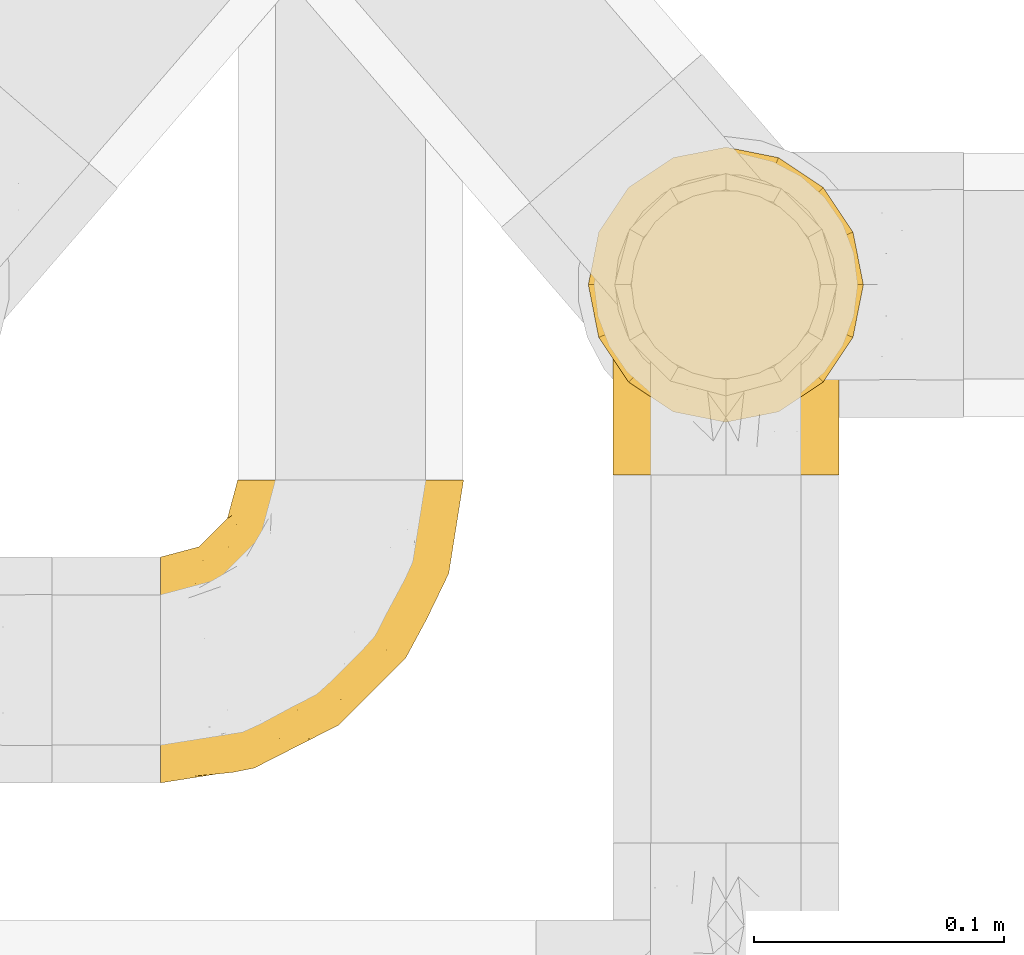
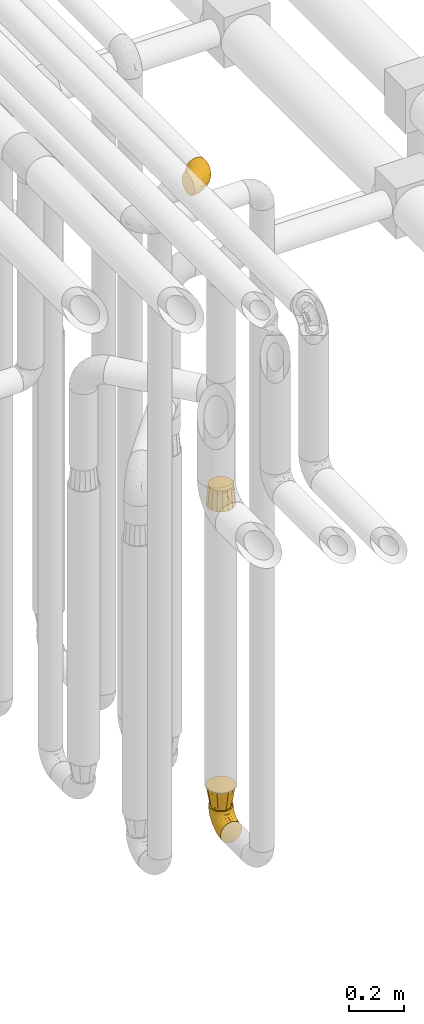
# One storey, part 196 of 827: 4 coverings.
"""IFC2X3 building model written with IfcOpenShell, lengths in millimetres."""

from ifc_helpers import new_model, entity, si_unit, converted_unit, derived_unit, direction, frame, origin, place, context, subcontext, project, spatial, faceted_brep, element, save


model = new_model("IFC2X3")

# Units and contexts
model_context = context("Model", 3, precision=0.01, world=origin(), true_north=direction((6.12303176911189e-17, 1.0)))
body_context = subcontext(model_context, "Body", "Model", "MODEL_VIEW")
ifc_project = project(units=[si_unit("LENGTHUNIT", "METRE", prefix="MILLI"), si_unit("AREAUNIT", "SQUARE_METRE"), si_unit("VOLUMEUNIT", "CUBIC_METRE"), converted_unit("PLANEANGLEUNIT", "DEGREE", entity("IfcRatioMeasure", 0.0174532925199433), si_unit("PLANEANGLEUNIT", "RADIAN"), dimensions=[0, 0, 0, 0, 0, 0, 0]), si_unit("MASSUNIT", "GRAM", prefix="KILO"), derived_unit("MASSDENSITYUNIT", [(si_unit("MASSUNIT", "GRAM", prefix="KILO"), 1), (si_unit("LENGTHUNIT", "METRE"), -3)]), derived_unit("MOMENTOFINERTIAUNIT", [(si_unit("LENGTHUNIT", "METRE"), 4)]), si_unit("TIMEUNIT", "SECOND"), si_unit("FREQUENCYUNIT", "HERTZ"), si_unit("THERMODYNAMICTEMPERATUREUNIT", "DEGREE_CELSIUS"), derived_unit("THERMALTRANSMITTANCEUNIT", [(si_unit("MASSUNIT", "GRAM", prefix="KILO"), 1), (si_unit("THERMODYNAMICTEMPERATUREUNIT", "KELVIN"), -1), (si_unit("TIMEUNIT", "SECOND"), -3)]), derived_unit("VOLUMETRICFLOWRATEUNIT", [(si_unit("LENGTHUNIT", "METRE"), 3), (si_unit("TIMEUNIT", "SECOND"), -1)]), derived_unit("MASSFLOWRATEUNIT", [(si_unit("MASSUNIT", "GRAM", prefix="KILO"), 1), (si_unit("TIMEUNIT", "SECOND"), -1)]), derived_unit("ROTATIONALFREQUENCYUNIT", [(si_unit("TIMEUNIT", "SECOND"), -1)]), si_unit("ELECTRICCURRENTUNIT", "AMPERE"), si_unit("ELECTRICVOLTAGEUNIT", "VOLT"), si_unit("POWERUNIT", "WATT"), si_unit("FORCEUNIT", "NEWTON", prefix="KILO"), si_unit("ILLUMINANCEUNIT", "LUX"), si_unit("LUMINOUSFLUXUNIT", "LUMEN"), si_unit("LUMINOUSINTENSITYUNIT", "CANDELA"), derived_unit("USERDEFINED", [(si_unit("MASSUNIT", "GRAM", prefix="KILO"), -1), (si_unit("LENGTHUNIT", "METRE"), -2), (si_unit("TIMEUNIT", "SECOND"), 3), (si_unit("LUMINOUSFLUXUNIT", "LUMEN"), 1)]), derived_unit("LINEARVELOCITYUNIT", [(si_unit("LENGTHUNIT", "METRE"), 1), (si_unit("TIMEUNIT", "SECOND"), -1)]), si_unit("PRESSUREUNIT", "PASCAL"), derived_unit("USERDEFINED", [(si_unit("LENGTHUNIT", "METRE"), -2), (si_unit("MASSUNIT", "GRAM", prefix="KILO"), 1), (si_unit("TIMEUNIT", "SECOND"), -2)]), derived_unit("LINEARFORCEUNIT", [(si_unit("MASSUNIT", "GRAM", prefix="KILO"), 1), (si_unit("LENGTHUNIT", "METRE"), 1), (si_unit("TIMEUNIT", "SECOND"), -2), (si_unit("LENGTHUNIT", "METRE"), -1)]), derived_unit("PLANARFORCEUNIT", [(si_unit("MASSUNIT", "GRAM", prefix="KILO"), 1), (si_unit("LENGTHUNIT", "METRE"), 1), (si_unit("TIMEUNIT", "SECOND"), -2), (si_unit("LENGTHUNIT", "METRE"), -2)])], contexts=[model_context])

# Site, building, storey
site_placement = place(None, origin())
site = spatial("IfcSite", under=ifc_project, at=site_placement, CompositionType="ELEMENT")
building_placement = place(site_placement, origin())
building = spatial("IfcBuilding", under=site, at=building_placement, CompositionType="ELEMENT")
storey_placement = place(building_placement, frame((0.0, 0.0, 28200.0)))
storey = spatial("IfcBuildingStorey", under=building, at=storey_placement, Name="08", CompositionType="ELEMENT", Elevation=28200.0)

# Coverings
covering_1_placement = place(storey_placement, frame((36928.29, 10002.61, 353.25)))
element("IfcCovering", 1, at=covering_1_placement, inside=storey, Name=":ADSK_", ObjectType=":ADSK_", PredefinedType="INSULATION", context=body_context, shape_type="Brep", body=[
    faceted_brep([(90.76, 87.65, 122.75), (87.42, 97.19, 122.75), (82.04, 105.75, 122.75), (74.89, 112.9, 122.75), (66.33, 118.28, 122.75), (56.79, 121.61, 122.75), (46.75, 122.75, 122.75), (36.69, 121.61, 122.75), (27.15, 118.27, 122.75), (18.59, 112.89, 122.75), (11.44, 105.74, 122.75), (6.06, 97.18, 122.75), (2.73, 87.64, 122.75), (1.6, 77.6, 122.75), (2.73, 67.54, 122.75), (6.07, 58.0, 122.75), (11.45, 49.44, 122.75), (18.6, 42.29, 122.75), (27.16, 36.91, 122.75), (36.7, 33.58, 122.75), (46.75, 32.45, 122.75), (56.8, 33.58, 122.75), (66.34, 36.92, 122.75), (74.9, 42.3, 122.75), (82.05, 49.45, 122.75), (87.43, 58.01, 122.75), (90.76, 67.55, 122.75), (91.9, 77.6, 122.75), (35.06, 1.6, 90.36), (24.17, 1.6, 85.85), (14.82, 1.6, 78.67), (7.64, 1.6, 69.32), (3.13, 1.6, 58.43), (1.6, 1.6, 46.75), (3.13, 1.6, 35.06), (7.64, 1.6, 24.17), (14.82, 1.6, 14.82), (24.17, 1.6, 7.64), (35.06, 1.6, 3.13), (46.75, 1.6, 1.6), (58.43, 1.6, 3.13), (69.32, 1.6, 7.64), (78.67, 1.6, 14.82), (85.85, 1.6, 24.17), (90.36, 1.6, 35.06), (91.9, 1.6, 46.75), (90.36, 1.6, 58.43), (85.85, 1.6, 69.32), (78.67, 1.6, 78.67), (69.32, 1.6, 85.85), (58.43, 1.6, 90.36), (46.75, 1.6, 91.9), (46.75, 99.61, 51.54), (55.2, 95.26, 47.17), (46.75, 86.21, 38.13), (46.75, 39.03, 7.52), (54.53, 30.75, 5.85), (46.75, 23.8, 5.11), (59.63, 60.8, 19.2), (62.07, 85.37, 38.98), (71.86, 73.64, 35.02), (62.65, 31.01, 8.21), (71.33, 49.14, 19.28), (72.93, 23.88, 12.19), (91.2, 82.74, 101.39), (86.31, 43.48, 34.43), (80.89, 29.47, 20.95), (79.49, 56.38, 30.74), (90.68, 72.18, 72.93), (86.84, 72.24, 56.64), (87.38, 87.6, 80.81), (76.87, 107.24, 93.43), (83.73, 101.1, 100.76), (81.03, 95.16, 74.27), (91.9, 71.81, 93.66), (91.9, 63.57, 81.33), (91.9, 55.34, 69.01), (91.03, 23.66, 40.87), (87.58, 20.55, 29.38), (56.52, 107.97, 67.05), (46.75, 116.82, 85.31), (60.4, 117.03, 93.68), (91.9, 30.68, 52.53), (91.9, 21.51, 50.71), (91.9, 12.33, 48.88), (67.87, 106.17, 72.77), (90.35, 52.37, 51.21), (69.57, 114.51, 101.18), (46.75, 119.23, 100.54), (79.91, 78.37, 48.74), (91.9, 75.46, 112.01), (91.9, 73.63, 102.83), (74.99, 101.51, 73.88), (46.75, 72.81, 24.73), (91.9, 43.01, 60.77), (88.53, 92.6, 103.08), (72.65, 91.86, 54.8), (46.75, 55.92, 16.13), (62.97, 99.01, 55.92), (46.75, 108.21, 68.42), (66.2, 32.05, 104.98), (56.6, 30.22, 108.58), (59.89, 23.37, 98.21), (90.95, 28.43, 61.56), (90.22, 16.44, 60.69), (76.64, 37.1, 100.0), (71.58, 28.88, 95.88), (79.99, 33.93, 90.81), (89.54, 50.17, 84.88), (89.97, 40.57, 73.29), (81.32, 47.62, 113.4), (74.56, 39.9, 109.8), (84.15, 47.92, 102.13), (90.37, 34.27, 67.29), (87.82, 24.65, 70.34), (90.98, 62.6, 95.15), (90.96, 66.18, 105.49), (85.14, 11.74, 71.5), (58.11, 13.89, 92.87), (46.75, 17.02, 96.03), (78.39, 15.86, 81.34), (88.22, 57.71, 107.44), (66.06, 9.11, 88.36), (68.6, 18.55, 90.43), (63.78, 34.74, 114.37), (88.42, 54.95, 98.41), (90.61, 57.35, 88.73), (83.8, 22.03, 76.89), (77.98, 24.8, 86.08), (91.22, 69.07, 112.64), (83.46, 42.31, 94.21), (46.75, 29.63, 112.22), (46.75, 28.31, 107.32), (84.66, 30.23, 79.95), (86.33, 40.13, 84.51), (46.75, 22.67, 101.67), (46.75, 12.12, 94.71), (15.1, 15.86, 81.34), (9.69, 22.03, 76.89), (15.52, 24.8, 86.08), (8.83, 30.23, 79.96), (35.39, 13.88, 92.87), (12.18, 47.61, 113.41), (1.6, 73.63, 102.83), (2.53, 66.17, 105.5), (2.27, 69.07, 112.64), (36.9, 30.22, 108.58), (27.31, 32.04, 104.98), (33.62, 23.36, 98.2), (5.07, 54.93, 98.4), (9.36, 47.91, 102.13), (5.27, 57.69, 107.44), (27.43, 9.1, 88.36), (1.6, 21.51, 50.71), (1.6, 12.33, 48.88), (10.05, 42.29, 94.22), (16.87, 37.09, 100.01), (8.35, 11.74, 71.5), (3.27, 16.44, 60.69), (1.6, 30.68, 52.53), (21.94, 28.86, 95.89), (29.72, 34.74, 114.37), (1.6, 63.57, 81.33), (1.6, 55.34, 69.01), (3.96, 50.17, 84.88), (1.6, 75.46, 112.01), (18.95, 39.89, 109.8), (2.54, 28.43, 61.56), (3.12, 34.27, 67.29), (1.6, 43.01, 60.77), (2.51, 62.59, 95.14), (3.52, 40.57, 73.29), (7.17, 40.13, 84.53), (1.6, 71.81, 93.66), (13.52, 33.92, 90.82), (2.88, 57.34, 88.73), (5.67, 24.65, 70.34), (24.89, 18.54, 90.43), (12.6, 29.47, 20.95), (7.18, 43.48, 34.43), (14.0, 56.4, 30.74), (22.16, 49.17, 19.29), (21.61, 73.69, 35.07), (3.14, 52.37, 51.21), (6.65, 72.26, 56.67), (20.82, 91.88, 54.85), (31.41, 85.36, 38.98), (5.91, 20.55, 29.38), (2.46, 23.66, 40.87), (33.87, 60.8, 19.2), (30.84, 31.02, 8.21), (38.96, 30.75, 5.85), (20.56, 23.9, 12.19), (2.81, 72.17, 72.93), (6.1, 87.59, 80.83), (2.29, 82.74, 101.39), (33.08, 117.03, 93.69), (16.61, 107.23, 93.43), (36.96, 107.97, 67.04), (9.75, 101.08, 100.76), (25.61, 106.17, 72.78), (30.5, 99.01, 55.93), (23.91, 114.5, 101.18), (12.45, 95.15, 74.27), (18.49, 101.5, 73.89), (4.96, 92.59, 103.09), (13.56, 78.38, 48.78), (38.28, 95.27, 47.19)], [[[0, 1, 2, 3, 4, 5, 6, 7, 8, 9, 10, 11, 12, 13, 14, 15, 16, 17, 18, 19, 20, 21, 22, 23, 24, 25, 26, 27]], [[28, 29, 30, 31, 32, 33, 34, 35, 36, 37, 38, 39, 40, 41, 42, 43, 44, 45, 46, 47, 48, 49, 50, 51]], [[52, 53, 54]], [[55, 56, 57]], [[58, 59, 60]], [[61, 62, 63]], [[27, 64, 0]], [[65, 66, 67]], [[41, 40, 61]], [[68, 69, 70]], [[66, 43, 42]], [[63, 42, 41]], [[71, 72, 73]], [[72, 2, 1]], [[68, 74, 75, 76]], [[45, 44, 77]], [[43, 78, 44]], [[79, 80, 81]], [[77, 82, 83, 84, 45]], [[79, 81, 85]], [[71, 2, 72]], [[65, 86, 77]], [[4, 81, 5]], [[66, 65, 78]], [[4, 3, 87]], [[81, 88, 5]], [[63, 66, 42]], [[68, 70, 64]], [[67, 60, 89]], [[71, 3, 2]], [[64, 27, 90, 91, 74]], [[92, 71, 73]], [[40, 57, 56]], [[59, 93, 54]], [[86, 76, 94, 82]], [[1, 0, 95]], [[58, 62, 61]], [[60, 96, 89]], [[85, 81, 87]], [[56, 97, 58]], [[65, 67, 69]], [[87, 81, 4]], [[67, 89, 69]], [[61, 63, 41]], [[95, 72, 1]], [[73, 72, 70]], [[69, 73, 70]], [[73, 89, 96]], [[3, 71, 87]], [[85, 87, 71]], [[58, 61, 56]], [[59, 58, 93]], [[76, 86, 68]], [[69, 89, 73]], [[68, 86, 69]], [[65, 69, 86]], [[68, 64, 74]], [[95, 64, 70]], [[98, 79, 85]], [[79, 52, 99, 80]], [[66, 62, 67]], [[62, 58, 60]], [[62, 60, 67]], [[59, 98, 96]], [[59, 96, 60]], [[96, 85, 92]], [[88, 81, 80]], [[88, 6, 5]], [[66, 63, 62]], [[64, 95, 0]], [[72, 95, 70]], [[77, 44, 78]], [[86, 82, 77]], [[40, 39, 57]], [[96, 98, 85]], [[40, 56, 61]], [[66, 78, 43]], [[77, 78, 65]], [[79, 98, 53]], [[96, 92, 73]], [[85, 71, 92]], [[97, 56, 55]], [[97, 93, 58]], [[53, 98, 59]], [[54, 53, 59]], [[79, 53, 52]], [[100, 101, 102]], [[46, 45, 84, 83]], [[103, 104, 82]], [[82, 104, 83]], [[105, 106, 107]], [[108, 109, 76]], [[110, 111, 112]], [[103, 113, 114]], [[115, 74, 116]], [[48, 47, 117]], [[118, 102, 119]], [[49, 48, 120]], [[74, 91, 116]], [[116, 121, 115]], [[49, 122, 50]], [[123, 106, 102]], [[124, 111, 22]], [[125, 126, 115]], [[23, 22, 111]], [[24, 110, 121]], [[120, 127, 128]], [[90, 26, 129]], [[27, 26, 90]], [[121, 125, 115]], [[24, 121, 25]], [[130, 105, 107]], [[129, 25, 116]], [[21, 20, 131]], [[120, 123, 122]], [[112, 105, 130]], [[50, 118, 51]], [[21, 124, 22]], [[101, 131, 132]], [[117, 120, 48]], [[24, 23, 110]], [[127, 114, 133]], [[75, 108, 76]], [[107, 134, 130]], [[133, 114, 113]], [[129, 116, 91]], [[25, 121, 116]], [[121, 112, 125]], [[75, 74, 115]], [[101, 135, 102]], [[131, 101, 21]], [[101, 100, 124]], [[128, 127, 133]], [[119, 136, 51, 118]], [[104, 47, 46]], [[83, 104, 46]], [[117, 104, 114]], [[101, 124, 21]], [[111, 124, 100]], [[102, 118, 123]], [[133, 134, 107]], [[111, 110, 23]], [[114, 104, 103]], [[94, 76, 109]], [[121, 110, 112]], [[122, 118, 50]], [[134, 109, 108]], [[133, 107, 128]], [[112, 108, 125]], [[126, 125, 108]], [[108, 75, 126]], [[75, 115, 126]], [[109, 134, 133]], [[130, 108, 112]], [[108, 130, 134]], [[105, 112, 111]], [[111, 100, 105]], [[106, 105, 100]], [[102, 106, 100]], [[128, 106, 123]], [[90, 129, 91]], [[25, 129, 26]], [[104, 117, 47]], [[117, 114, 127]], [[82, 94, 103]], [[113, 94, 109]], [[94, 113, 103]], [[133, 113, 109]], [[106, 128, 107]], [[123, 120, 128]], [[120, 122, 49]], [[118, 122, 123]], [[135, 101, 132]], [[135, 119, 102]], [[117, 127, 120]], [[30, 29, 137]], [[138, 139, 140]], [[51, 136, 119, 141]], [[142, 17, 16]], [[143, 144, 145]], [[146, 147, 148]], [[149, 150, 151]], [[152, 29, 28]], [[33, 32, 153, 154]], [[150, 155, 156]], [[157, 31, 30]], [[153, 158, 159]], [[29, 152, 137]], [[148, 141, 119]], [[156, 160, 147]], [[148, 135, 146]], [[137, 138, 157]], [[19, 161, 146]], [[162, 163, 164]], [[14, 13, 165]], [[153, 32, 158]], [[147, 161, 166]], [[18, 17, 166]], [[167, 168, 169]], [[166, 150, 156]], [[151, 150, 142]], [[151, 170, 149]], [[151, 16, 15]], [[171, 140, 172]], [[165, 143, 145]], [[173, 170, 144]], [[142, 166, 17]], [[19, 131, 20]], [[144, 170, 151]], [[18, 161, 19]], [[173, 144, 143]], [[140, 139, 174]], [[171, 164, 163]], [[164, 172, 155]], [[151, 15, 144]], [[145, 15, 14]], [[173, 162, 170]], [[149, 175, 164]], [[19, 146, 131]], [[132, 131, 146]], [[160, 148, 147]], [[159, 158, 167]], [[135, 132, 146]], [[158, 32, 31]], [[157, 158, 31]], [[167, 158, 176]], [[166, 161, 18]], [[146, 161, 147]], [[148, 177, 141]], [[171, 168, 140]], [[171, 163, 169]], [[151, 142, 16]], [[166, 142, 150]], [[152, 141, 177]], [[51, 141, 28]], [[138, 140, 176]], [[172, 140, 174]], [[175, 149, 170]], [[164, 150, 149]], [[170, 162, 175]], [[162, 164, 175]], [[155, 172, 174]], [[171, 172, 164]], [[155, 174, 156]], [[164, 155, 150]], [[160, 156, 174]], [[147, 166, 156]], [[139, 160, 174]], [[148, 160, 177]], [[15, 145, 144]], [[165, 145, 14]], [[137, 157, 30]], [[158, 157, 176]], [[168, 167, 176]], [[169, 159, 167]], [[140, 168, 176]], [[169, 168, 171]], [[137, 177, 139]], [[160, 139, 177]], [[141, 152, 28]], [[137, 152, 177]], [[148, 119, 135]], [[157, 138, 176]], [[139, 138, 137]], [[178, 179, 180]], [[181, 180, 182]], [[179, 183, 184]], [[185, 186, 182]], [[187, 188, 179]], [[188, 33, 154, 153, 159]], [[181, 189, 190]], [[35, 34, 187]], [[191, 38, 190]], [[192, 178, 181]], [[179, 184, 180]], [[192, 190, 37]], [[37, 190, 38]], [[36, 35, 178]], [[54, 93, 186]], [[35, 187, 178]], [[193, 194, 184]], [[195, 173, 143, 165, 13]], [[195, 193, 173]], [[193, 163, 162, 173]], [[13, 12, 195]], [[8, 7, 196]], [[9, 197, 10]], [[198, 80, 99, 52]], [[196, 7, 88]], [[197, 199, 10]], [[182, 189, 181]], [[200, 198, 201]], [[200, 196, 198]], [[9, 8, 202]], [[194, 199, 203]], [[192, 37, 36]], [[80, 196, 88]], [[183, 159, 169, 163]], [[188, 34, 33]], [[202, 200, 197]], [[185, 203, 204]], [[202, 8, 196]], [[10, 199, 11]], [[12, 11, 205]], [[38, 191, 57]], [[189, 97, 191]], [[203, 199, 197]], [[205, 199, 194]], [[204, 203, 197]], [[184, 203, 206]], [[200, 202, 196]], [[197, 9, 202]], [[207, 54, 186]], [[97, 55, 191]], [[194, 203, 184]], [[183, 163, 193]], [[184, 206, 180]], [[183, 193, 184]], [[205, 195, 12]], [[193, 195, 194]], [[80, 198, 196]], [[207, 186, 201]], [[182, 180, 206]], [[181, 178, 180]], [[185, 182, 206]], [[182, 186, 189]], [[203, 185, 206]], [[185, 200, 201]], [[7, 6, 88]], [[178, 192, 36]], [[190, 192, 181]], [[199, 205, 11]], [[195, 205, 194]], [[159, 183, 188]], [[179, 188, 183]], [[57, 191, 55]], [[57, 39, 38]], [[189, 191, 190]], [[188, 187, 34]], [[178, 187, 179]], [[186, 93, 189]], [[197, 200, 204]], [[185, 204, 200]], [[189, 93, 97]], [[207, 198, 52]], [[185, 201, 186]], [[198, 207, 201]], [[54, 207, 52]]]),
])
covering_2_placement = place(storey_placement, frame((36918.44, 10023.61, 1811.0)))
element("IfcCovering", 2, at=covering_2_placement, inside=storey, Name=":ADSK_", ObjectType=":ADSK_", PredefinedType="INSULATION", context=body_context, shape_type="Brep", body=[
    faceted_brep([(56.6, 104.1, 89.0), (47.51, 102.29, 89.0), (38.42, 100.48, 89.0), (30.71, 95.33, 89.0), (23.01, 90.18, 89.0), (17.86, 82.48, 89.0), (12.71, 74.77, 89.0), (10.9, 65.68, 89.0), (9.1, 56.6, 89.0), (10.9, 47.51, 89.0), (12.71, 38.42, 89.0), (17.86, 30.71, 89.0), (23.01, 23.01, 89.0), (30.71, 17.86, 89.0), (38.42, 12.71, 89.0), (47.51, 10.9, 89.0), (56.6, 9.1, 89.0), (65.68, 10.9, 89.0), (74.77, 12.71, 89.0), (82.48, 17.86, 89.0), (90.18, 23.01, 89.0), (95.33, 30.71, 89.0), (100.48, 38.42, 89.0), (102.29, 47.51, 89.0), (104.1, 56.6, 89.0), (102.29, 65.68, 89.0), (100.48, 74.77, 89.0), (95.33, 82.48, 89.0), (90.18, 90.18, 89.0), (82.48, 95.33, 89.0), (74.77, 100.48, 89.0), (65.68, 102.29, 89.0), (77.64, 5.78, 0.0), (69.69, 4.2, 0.0), (56.6, 1.6, 0.0), (43.51, 4.2, 0.0), (35.55, 5.78, 0.0), (26.63, 11.74, 0.0), (17.7, 17.7, 0.0), (11.74, 26.63, 0.0), (5.78, 35.55, 0.0), (4.2, 43.51, 0.0), (1.6, 56.6, 0.0), (4.2, 69.69, 0.0), (5.78, 77.64, 0.0), (11.74, 86.56, 0.0), (17.7, 95.49, 0.0), (26.63, 101.45, 0.0), (35.55, 107.41, 0.0), (43.51, 108.99, 0.0), (56.6, 111.6, 0.0), (69.69, 108.99, 0.0), (77.64, 107.41, 0.0), (86.56, 101.45, 0.0), (95.49, 95.49, 0.0), (101.45, 86.56, 0.0), (107.41, 77.64, 0.0), (108.99, 69.69, 0.0), (111.6, 56.6, 0.0), (108.99, 43.51, 0.0), (107.41, 35.55, 0.0), (101.45, 26.63, 0.0), (95.49, 17.7, 0.0), (86.56, 11.74, 0.0)], [[[0, 1, 2, 3, 4, 5, 6, 7, 8, 9, 10, 11, 12, 13, 14, 15, 16, 17, 18, 19, 20, 21, 22, 23, 24, 25, 26, 27, 28, 29, 30, 31]], [[32, 33, 34, 35, 36, 37, 38, 39, 40, 41, 42, 43, 44, 45, 46, 47, 48, 49, 50, 51, 52, 53, 54, 55, 56, 57, 58, 59, 60, 61, 62, 63]], [[6, 44, 43, 42, 8, 7]], [[5, 4, 46, 45, 44, 6]], [[1, 0, 50, 49, 48, 2]], [[4, 3, 2, 48, 47, 46]], [[14, 36, 35, 34, 16, 15]], [[13, 12, 38, 37, 36, 14]], [[9, 8, 42, 41, 40, 10]], [[12, 11, 10, 40, 39, 38]], [[22, 60, 59, 58, 24, 23]], [[21, 20, 62, 61, 60, 22]], [[17, 16, 34, 33, 32, 18]], [[20, 19, 18, 32, 63, 62]], [[30, 52, 51, 50, 0, 31]], [[29, 28, 54, 53, 52, 30]], [[25, 24, 58, 57, 56, 26]], [[28, 27, 26, 56, 55, 54]]]),
])
covering_3_placement = place(storey_placement, frame((36918.44, 10023.61, 476.0)))
element("IfcCovering", 3, at=covering_3_placement, inside=storey, Name=":ADSK_", ObjectType=":ADSK_", PredefinedType="INSULATION", context=body_context, shape_type="Brep", body=[
    faceted_brep([(77.64, 107.41, 89.0), (67.12, 109.5, 89.0), (56.6, 111.6, 89.0), (46.07, 109.5, 89.0), (35.55, 107.41, 89.0), (26.63, 101.45, 89.0), (17.7, 95.49, 89.0), (11.74, 86.56, 89.0), (5.78, 77.64, 89.0), (3.69, 67.12, 89.0), (1.6, 56.6, 89.0), (3.69, 46.07, 89.0), (5.78, 35.55, 89.0), (11.74, 26.63, 89.0), (17.7, 17.7, 89.0), (26.63, 11.74, 89.0), (35.55, 5.78, 89.0), (46.07, 3.69, 89.0), (56.6, 1.6, 89.0), (67.12, 3.69, 89.0), (77.64, 5.78, 89.0), (86.56, 11.74, 89.0), (95.49, 17.7, 89.0), (101.45, 26.63, 89.0), (107.41, 35.55, 89.0), (109.5, 46.07, 89.0), (111.6, 56.6, 89.0), (109.5, 67.12, 89.0), (107.41, 77.64, 89.0), (101.45, 86.56, 89.0), (95.49, 95.49, 89.0), (86.56, 101.45, 89.0), (91.24, 36.6, 0.0), (83.92, 29.27, 0.0), (76.6, 21.95, 0.0), (66.6, 19.27, 0.0), (56.6, 16.6, 0.0), (46.6, 19.27, 0.0), (36.6, 21.95, 0.0), (29.27, 29.27, 0.0), (21.95, 36.6, 0.0), (19.27, 46.6, 0.0), (16.6, 56.6, 0.0), (19.27, 66.6, 0.0), (21.95, 76.6, 0.0), (29.27, 83.92, 0.0), (36.6, 91.24, 0.0), (46.6, 93.92, 0.0), (56.6, 96.6, 0.0), (66.6, 93.92, 0.0), (76.6, 91.24, 0.0), (83.92, 83.92, 0.0), (91.24, 76.6, 0.0), (93.92, 66.6, 0.0), (96.6, 56.6, 0.0), (93.92, 46.6, 0.0)], [[[0, 1, 2, 3, 4, 5, 6, 7, 8, 9, 10, 11, 12, 13, 14, 15, 16, 17, 18, 19, 20, 21, 22, 23, 24, 25, 26, 27, 28, 29, 30, 31]], [[32, 33, 34, 35, 36, 37, 38, 39, 40, 41, 42, 43, 44, 45, 46, 47, 48, 49, 50, 51, 52, 53, 54, 55]], [[3, 2, 48]], [[44, 7, 45]], [[45, 5, 46]], [[48, 47, 3]], [[6, 45, 7]], [[44, 8, 7]], [[5, 45, 6]], [[42, 9, 43]], [[5, 4, 46]], [[47, 46, 4]], [[9, 42, 10]], [[8, 44, 43]], [[9, 8, 43]], [[47, 4, 3]], [[11, 10, 42]], [[38, 15, 39]], [[39, 13, 40]], [[42, 41, 11]], [[14, 39, 15]], [[38, 16, 15]], [[13, 39, 14]], [[36, 17, 37]], [[13, 12, 40]], [[41, 40, 12]], [[17, 36, 18]], [[16, 38, 37]], [[17, 16, 37]], [[41, 12, 11]], [[19, 18, 36]], [[32, 23, 33]], [[33, 21, 34]], [[36, 35, 19]], [[22, 33, 23]], [[32, 24, 23]], [[21, 33, 22]], [[54, 25, 55]], [[21, 20, 34]], [[35, 34, 20]], [[25, 54, 26]], [[24, 32, 55]], [[25, 24, 55]], [[35, 20, 19]], [[27, 26, 54]], [[50, 31, 51]], [[51, 29, 52]], [[54, 53, 27]], [[30, 51, 31]], [[50, 0, 31]], [[29, 51, 30]], [[48, 1, 49]], [[29, 28, 52]], [[53, 52, 28]], [[1, 48, 2]], [[0, 50, 49]], [[1, 0, 49]], [[53, 28, 27]]]),
])
covering_4_placement = place(storey_placement, frame((36747.44, 9879.43, 3353.25)))
element("IfcCovering", 4, at=covering_4_placement, inside=storey, Name=":ADSK_", ObjectType=":ADSK_", PredefinedType="INSULATION", context=body_context, shape_type="Brep", body=[
    faceted_brep([(87.65, 122.75, 90.76), (97.19, 122.75, 87.42), (105.75, 122.75, 82.04), (112.9, 122.75, 74.89), (118.28, 122.75, 66.33), (121.61, 122.75, 56.79), (122.75, 122.75, 46.75), (121.61, 122.75, 36.69), (118.27, 122.75, 27.15), (112.89, 122.75, 18.59), (105.74, 122.75, 11.44), (97.18, 122.75, 6.06), (87.64, 122.75, 2.73), (77.6, 122.75, 1.6), (67.54, 122.75, 2.73), (58.0, 122.75, 6.07), (49.44, 122.75, 11.45), (42.29, 122.75, 18.6), (36.91, 122.75, 27.16), (33.58, 122.75, 36.7), (32.45, 122.75, 46.75), (33.58, 122.75, 56.8), (36.92, 122.75, 66.34), (42.3, 122.75, 74.9), (49.45, 122.75, 82.05), (58.01, 122.75, 87.43), (67.55, 122.75, 90.76), (77.6, 122.75, 91.9), (1.6, 90.36, 35.06), (1.6, 85.85, 24.17), (1.6, 78.67, 14.82), (1.6, 69.32, 7.64), (1.6, 58.43, 3.13), (1.6, 46.75, 1.6), (1.6, 35.06, 3.13), (1.6, 24.17, 7.64), (1.6, 14.82, 14.82), (1.6, 7.64, 24.17), (1.6, 3.13, 35.06), (1.6, 1.6, 46.75), (1.6, 3.13, 58.43), (1.6, 7.64, 69.32), (1.6, 14.82, 78.67), (1.6, 24.17, 85.85), (1.6, 35.06, 90.36), (1.6, 46.75, 91.9), (1.6, 58.43, 90.36), (1.6, 69.32, 85.85), (1.6, 78.67, 78.67), (1.6, 85.85, 69.32), (1.6, 90.36, 58.43), (1.6, 91.9, 46.75), (99.61, 51.54, 46.75), (95.26, 47.17, 55.2), (86.21, 38.13, 46.75), (39.03, 7.52, 46.75), (30.75, 5.85, 54.53), (23.8, 5.11, 46.75), (60.8, 19.2, 59.63), (85.37, 38.98, 62.07), (73.64, 35.02, 71.86), (31.01, 8.21, 62.65), (49.14, 19.28, 71.33), (23.88, 12.19, 72.93), (82.74, 101.39, 91.2), (43.48, 34.43, 86.31), (29.47, 20.95, 80.89), (56.38, 30.74, 79.49), (72.18, 72.93, 90.68), (72.24, 56.64, 86.84), (87.6, 80.81, 87.38), (107.24, 93.43, 76.87), (101.1, 100.76, 83.73), (95.16, 74.27, 81.03), (71.81, 93.66, 91.9), (63.57, 81.33, 91.9), (55.34, 69.01, 91.9), (23.66, 40.87, 91.03), (20.55, 29.38, 87.58), (107.97, 67.05, 56.52), (116.82, 85.31, 46.75), (117.03, 93.68, 60.4), (30.68, 52.53, 91.9), (21.51, 50.71, 91.9), (12.33, 48.88, 91.9), (106.17, 72.77, 67.87), (52.37, 51.21, 90.35), (114.51, 101.18, 69.57), (119.23, 100.54, 46.75), (78.37, 48.74, 79.91), (75.46, 112.01, 91.9), (73.63, 102.83, 91.9), (101.51, 73.88, 74.99), (72.81, 24.73, 46.75), (43.01, 60.77, 91.9), (92.6, 103.08, 88.53), (91.86, 54.8, 72.65), (55.92, 16.13, 46.75), (99.01, 55.92, 62.97), (108.21, 68.42, 46.75), (32.05, 104.98, 66.2), (30.22, 108.58, 56.6), (23.37, 98.21, 59.89), (28.43, 61.56, 90.95), (16.44, 60.69, 90.22), (37.1, 100.0, 76.64), (28.88, 95.88, 71.58), (33.93, 90.81, 79.99), (50.17, 84.88, 89.54), (40.57, 73.29, 89.97), (47.62, 113.4, 81.32), (39.9, 109.8, 74.56), (47.92, 102.13, 84.15), (34.27, 67.29, 90.37), (24.65, 70.34, 87.82), (62.6, 95.15, 90.98), (66.18, 105.49, 90.96), (11.74, 71.5, 85.14), (13.89, 92.87, 58.11), (17.02, 96.03, 46.75), (15.86, 81.34, 78.39), (57.71, 107.44, 88.22), (9.11, 88.36, 66.06), (18.55, 90.43, 68.6), (34.74, 114.37, 63.78), (54.95, 98.41, 88.42), (57.35, 88.73, 90.61), (22.03, 76.89, 83.8), (24.8, 86.08, 77.98), (69.07, 112.64, 91.22), (42.31, 94.21, 83.46), (29.63, 112.22, 46.75), (28.31, 107.32, 46.75), (30.23, 79.95, 84.66), (40.13, 84.51, 86.33), (22.67, 101.67, 46.75), (12.12, 94.71, 46.75), (15.86, 81.34, 15.1), (22.03, 76.89, 9.69), (24.8, 86.08, 15.52), (30.23, 79.96, 8.83), (13.88, 92.87, 35.39), (47.61, 113.41, 12.18), (73.63, 102.83, 1.6), (66.17, 105.5, 2.53), (69.07, 112.64, 2.27), (30.22, 108.58, 36.9), (32.04, 104.98, 27.31), (23.36, 98.2, 33.62), (54.93, 98.4, 5.07), (47.91, 102.13, 9.36), (57.69, 107.44, 5.27), (9.1, 88.36, 27.43), (21.51, 50.71, 1.6), (12.33, 48.88, 1.6), (42.29, 94.22, 10.05), (37.09, 100.01, 16.87), (11.74, 71.5, 8.35), (16.44, 60.69, 3.27), (30.68, 52.53, 1.6), (28.86, 95.89, 21.94), (34.74, 114.37, 29.72), (63.57, 81.33, 1.6), (55.34, 69.01, 1.6), (50.17, 84.88, 3.96), (75.46, 112.01, 1.6), (39.89, 109.8, 18.95), (28.43, 61.56, 2.54), (34.27, 67.29, 3.12), (43.01, 60.77, 1.6), (62.59, 95.14, 2.51), (40.57, 73.29, 3.52), (40.13, 84.53, 7.17), (71.81, 93.66, 1.6), (33.92, 90.82, 13.52), (57.34, 88.73, 2.88), (24.65, 70.34, 5.67), (18.54, 90.43, 24.89), (29.47, 20.95, 12.6), (43.48, 34.43, 7.18), (56.4, 30.74, 14.0), (49.17, 19.29, 22.16), (73.69, 35.07, 21.61), (52.37, 51.21, 3.14), (72.26, 56.67, 6.65), (91.88, 54.85, 20.82), (85.36, 38.98, 31.41), (20.55, 29.38, 5.91), (23.66, 40.87, 2.46), (60.8, 19.2, 33.87), (31.02, 8.21, 30.84), (30.75, 5.85, 38.96), (23.9, 12.19, 20.56), (72.17, 72.93, 2.81), (87.59, 80.83, 6.1), (82.74, 101.39, 2.29), (117.03, 93.69, 33.08), (107.23, 93.43, 16.61), (107.97, 67.04, 36.96), (101.08, 100.76, 9.75), (106.17, 72.78, 25.61), (99.01, 55.93, 30.5), (114.5, 101.18, 23.91), (95.15, 74.27, 12.45), (101.5, 73.89, 18.49), (92.59, 103.09, 4.96), (78.38, 48.78, 13.56), (95.27, 47.19, 38.28)], [[[0, 1, 2, 3, 4, 5, 6, 7, 8, 9, 10, 11, 12, 13, 14, 15, 16, 17, 18, 19, 20, 21, 22, 23, 24, 25, 26, 27]], [[28, 29, 30, 31, 32, 33, 34, 35, 36, 37, 38, 39, 40, 41, 42, 43, 44, 45, 46, 47, 48, 49, 50, 51]], [[52, 53, 54]], [[55, 56, 57]], [[58, 59, 60]], [[61, 62, 63]], [[27, 64, 0]], [[65, 66, 67]], [[41, 40, 61]], [[68, 69, 70]], [[66, 43, 42]], [[63, 42, 41]], [[71, 72, 73]], [[72, 2, 1]], [[68, 74, 75, 76]], [[45, 44, 77]], [[43, 78, 44]], [[79, 80, 81]], [[77, 82, 83, 84, 45]], [[79, 81, 85]], [[71, 2, 72]], [[65, 86, 77]], [[4, 81, 5]], [[66, 65, 78]], [[4, 3, 87]], [[81, 88, 5]], [[63, 66, 42]], [[68, 70, 64]], [[67, 60, 89]], [[71, 3, 2]], [[64, 27, 90, 91, 74]], [[92, 71, 73]], [[40, 57, 56]], [[59, 93, 54]], [[86, 76, 94, 82]], [[1, 0, 95]], [[58, 62, 61]], [[60, 96, 89]], [[85, 81, 87]], [[56, 97, 58]], [[65, 67, 69]], [[87, 81, 4]], [[67, 89, 69]], [[61, 63, 41]], [[95, 72, 1]], [[73, 72, 70]], [[69, 73, 70]], [[73, 89, 96]], [[3, 71, 87]], [[85, 87, 71]], [[58, 61, 56]], [[59, 58, 93]], [[76, 86, 68]], [[69, 89, 73]], [[68, 86, 69]], [[65, 69, 86]], [[68, 64, 74]], [[95, 64, 70]], [[98, 79, 85]], [[79, 52, 99, 80]], [[66, 62, 67]], [[62, 58, 60]], [[62, 60, 67]], [[59, 98, 96]], [[59, 96, 60]], [[96, 85, 92]], [[88, 81, 80]], [[88, 6, 5]], [[66, 63, 62]], [[64, 95, 0]], [[72, 95, 70]], [[77, 44, 78]], [[86, 82, 77]], [[40, 39, 57]], [[96, 98, 85]], [[40, 56, 61]], [[66, 78, 43]], [[77, 78, 65]], [[79, 98, 53]], [[96, 92, 73]], [[85, 71, 92]], [[97, 56, 55]], [[97, 93, 58]], [[53, 98, 59]], [[54, 53, 59]], [[79, 53, 52]], [[100, 101, 102]], [[46, 45, 84, 83]], [[103, 104, 82]], [[82, 104, 83]], [[105, 106, 107]], [[108, 109, 76]], [[110, 111, 112]], [[103, 113, 114]], [[115, 74, 116]], [[48, 47, 117]], [[118, 102, 119]], [[49, 48, 120]], [[74, 91, 116]], [[116, 121, 115]], [[49, 122, 50]], [[123, 106, 102]], [[124, 111, 22]], [[125, 126, 115]], [[23, 22, 111]], [[24, 110, 121]], [[120, 127, 128]], [[90, 26, 129]], [[27, 26, 90]], [[121, 125, 115]], [[24, 121, 25]], [[130, 105, 107]], [[129, 25, 116]], [[21, 20, 131]], [[120, 123, 122]], [[112, 105, 130]], [[50, 118, 51]], [[21, 124, 22]], [[101, 131, 132]], [[117, 120, 48]], [[24, 23, 110]], [[127, 114, 133]], [[75, 108, 76]], [[107, 134, 130]], [[133, 114, 113]], [[129, 116, 91]], [[25, 121, 116]], [[121, 112, 125]], [[75, 74, 115]], [[101, 135, 102]], [[131, 101, 21]], [[101, 100, 124]], [[128, 127, 133]], [[119, 136, 51, 118]], [[104, 47, 46]], [[83, 104, 46]], [[117, 104, 114]], [[101, 124, 21]], [[111, 124, 100]], [[102, 118, 123]], [[133, 134, 107]], [[111, 110, 23]], [[114, 104, 103]], [[94, 76, 109]], [[121, 110, 112]], [[122, 118, 50]], [[134, 109, 108]], [[133, 107, 128]], [[112, 108, 125]], [[126, 125, 108]], [[108, 75, 126]], [[75, 115, 126]], [[109, 134, 133]], [[130, 108, 112]], [[108, 130, 134]], [[105, 112, 111]], [[111, 100, 105]], [[106, 105, 100]], [[102, 106, 100]], [[128, 106, 123]], [[90, 129, 91]], [[25, 129, 26]], [[104, 117, 47]], [[117, 114, 127]], [[82, 94, 103]], [[113, 94, 109]], [[94, 113, 103]], [[133, 113, 109]], [[106, 128, 107]], [[123, 120, 128]], [[120, 122, 49]], [[118, 122, 123]], [[135, 101, 132]], [[135, 119, 102]], [[117, 127, 120]], [[30, 29, 137]], [[138, 139, 140]], [[51, 136, 119, 141]], [[142, 17, 16]], [[143, 144, 145]], [[146, 147, 148]], [[149, 150, 151]], [[152, 29, 28]], [[33, 32, 153, 154]], [[150, 155, 156]], [[157, 31, 30]], [[153, 158, 159]], [[29, 152, 137]], [[148, 141, 119]], [[156, 160, 147]], [[148, 135, 146]], [[137, 138, 157]], [[19, 161, 146]], [[162, 163, 164]], [[14, 13, 165]], [[153, 32, 158]], [[147, 161, 166]], [[18, 17, 166]], [[167, 168, 169]], [[166, 150, 156]], [[151, 150, 142]], [[151, 170, 149]], [[151, 16, 15]], [[171, 140, 172]], [[165, 143, 145]], [[173, 170, 144]], [[142, 166, 17]], [[19, 131, 20]], [[144, 170, 151]], [[18, 161, 19]], [[173, 144, 143]], [[140, 139, 174]], [[171, 164, 163]], [[164, 172, 155]], [[151, 15, 144]], [[145, 15, 14]], [[173, 162, 170]], [[149, 175, 164]], [[19, 146, 131]], [[132, 131, 146]], [[160, 148, 147]], [[159, 158, 167]], [[135, 132, 146]], [[158, 32, 31]], [[157, 158, 31]], [[167, 158, 176]], [[166, 161, 18]], [[146, 161, 147]], [[148, 177, 141]], [[171, 168, 140]], [[171, 163, 169]], [[151, 142, 16]], [[166, 142, 150]], [[152, 141, 177]], [[51, 141, 28]], [[138, 140, 176]], [[172, 140, 174]], [[175, 149, 170]], [[164, 150, 149]], [[170, 162, 175]], [[162, 164, 175]], [[155, 172, 174]], [[171, 172, 164]], [[155, 174, 156]], [[164, 155, 150]], [[160, 156, 174]], [[147, 166, 156]], [[139, 160, 174]], [[148, 160, 177]], [[15, 145, 144]], [[165, 145, 14]], [[137, 157, 30]], [[158, 157, 176]], [[168, 167, 176]], [[169, 159, 167]], [[140, 168, 176]], [[169, 168, 171]], [[137, 177, 139]], [[160, 139, 177]], [[141, 152, 28]], [[137, 152, 177]], [[148, 119, 135]], [[157, 138, 176]], [[139, 138, 137]], [[178, 179, 180]], [[181, 180, 182]], [[179, 183, 184]], [[185, 186, 182]], [[187, 188, 179]], [[188, 33, 154, 153, 159]], [[181, 189, 190]], [[35, 34, 187]], [[191, 38, 190]], [[192, 178, 181]], [[179, 184, 180]], [[192, 190, 37]], [[37, 190, 38]], [[36, 35, 178]], [[54, 93, 186]], [[35, 187, 178]], [[193, 194, 184]], [[195, 173, 143, 165, 13]], [[195, 193, 173]], [[193, 163, 162, 173]], [[13, 12, 195]], [[8, 7, 196]], [[9, 197, 10]], [[198, 80, 99, 52]], [[196, 7, 88]], [[197, 199, 10]], [[182, 189, 181]], [[200, 198, 201]], [[200, 196, 198]], [[9, 8, 202]], [[194, 199, 203]], [[192, 37, 36]], [[80, 196, 88]], [[183, 159, 169, 163]], [[188, 34, 33]], [[202, 200, 197]], [[185, 203, 204]], [[202, 8, 196]], [[10, 199, 11]], [[12, 11, 205]], [[38, 191, 57]], [[189, 97, 191]], [[203, 199, 197]], [[205, 199, 194]], [[204, 203, 197]], [[184, 203, 206]], [[200, 202, 196]], [[197, 9, 202]], [[207, 54, 186]], [[97, 55, 191]], [[194, 203, 184]], [[183, 163, 193]], [[184, 206, 180]], [[183, 193, 184]], [[205, 195, 12]], [[193, 195, 194]], [[80, 198, 196]], [[207, 186, 201]], [[182, 180, 206]], [[181, 178, 180]], [[185, 182, 206]], [[182, 186, 189]], [[203, 185, 206]], [[185, 200, 201]], [[7, 6, 88]], [[178, 192, 36]], [[190, 192, 181]], [[199, 205, 11]], [[195, 205, 194]], [[159, 183, 188]], [[179, 188, 183]], [[57, 191, 55]], [[57, 39, 38]], [[189, 191, 190]], [[188, 187, 34]], [[178, 187, 179]], [[186, 93, 189]], [[197, 200, 204]], [[185, 204, 200]], [[189, 93, 97]], [[207, 198, 52]], [[185, 201, 186]], [[198, 207, 201]], [[54, 207, 52]]]),
])

save(model, "model.ifc")
